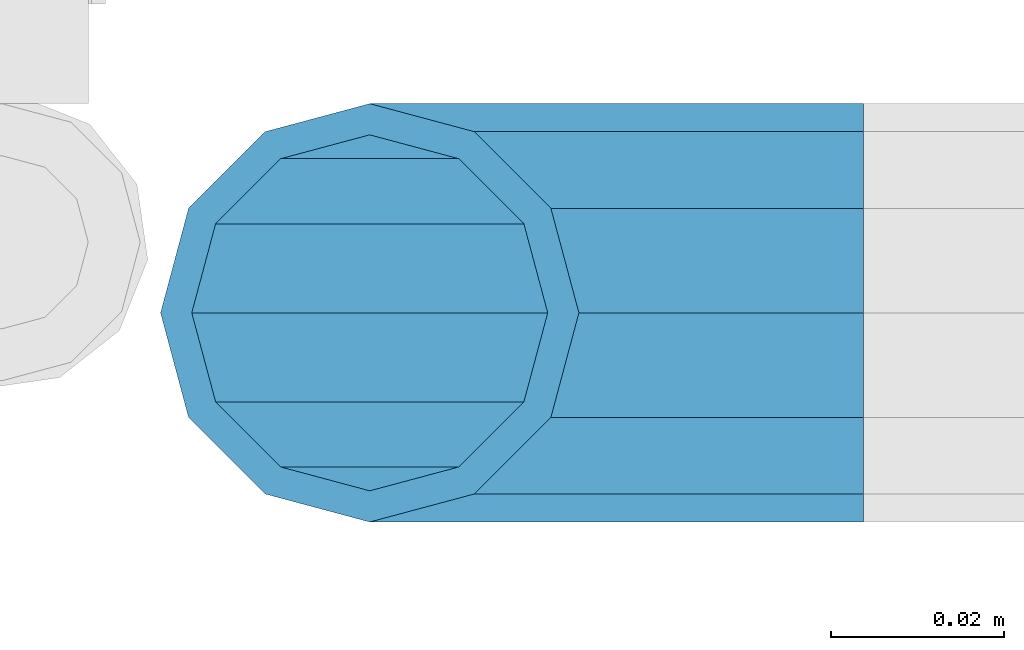
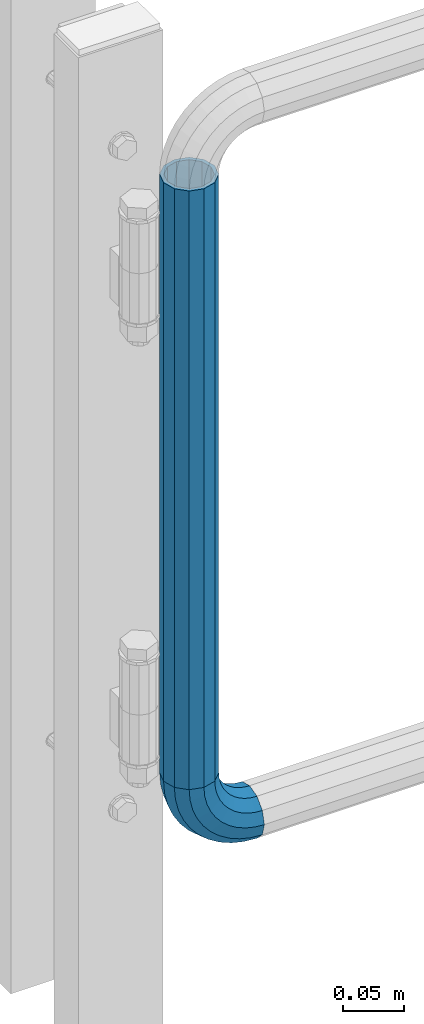
# One storey, part 145 of 208: 1 beam, 1 member.
"""IFC2X3 building model written with IfcOpenShell, lengths in millimetres."""

import ifcopenshell
import ifcopenshell.guid

model = None  # the IFC model being written
_history = None  # IfcOwnerHistory: only IFC2X3 demands one
_inside = {}  # id of a spatial element -> (the spatial element, [elements in it])
_under = {}  # id of a project, library or spatial element -> (it, [spatial elements below it])
_declared = {}  # id of a project -> (the project, [libraries it declares])
_typed = {}  # id of a type object -> (the type object, [elements of that type])
_made_of = {}  # id of a material, layer set ... -> (it, [elements and type objects made of it])


def new_model(schema):
    """Start an empty IFC model of exactly this schema.

    Asked for "IFC4X3", IfcOpenShell would pick the latest addendum, in which some entities
    have other attributes; the version numbers below select the first issue.
    IFC2X3 requires an IfcOwnerHistory on every rooted entity: one is made here for all.
    """
    global model, _history
    if schema == "IFC4X3":
        model = ifcopenshell.file(schema_version=(4, 3, 0, 0))
    else:
        model = ifcopenshell.file(schema=schema)
    _inside.clear()
    _under.clear()
    _declared.clear()
    _typed.clear()
    _made_of.clear()
    _history = None
    if model.schema == "IFC2X3":
        org = make("IfcOrganization", Name="unknown")
        user = make(
            "IfcPersonAndOrganization",
            ThePerson=make("IfcPerson", FamilyName="unknown"),
            TheOrganization=org,
        )
        app = make(
            "IfcApplication",
            ApplicationDeveloper=org,
            Version="unknown",
            ApplicationFullName="unknown",
            ApplicationIdentifier="unknown",
        )
        _history = make(
            "IfcOwnerHistory",
            OwningUser=user,
            OwningApplication=app,
            ChangeAction="ADDED",
            CreationDate=0,
        )
    return model


def make(cls, **values):
    """One entity of the class cls with the attributes given. An attribute that is None is left unset."""
    return model.create_entity(
        cls, **{name: value for name, value in values.items() if value is not None}
    )


def rooted(cls, **values):
    """An entity with a GlobalId (a new one), such as an element, a storey or a relation."""
    return make(cls, GlobalId=ifcopenshell.guid.new(), OwnerHistory=_history, **values)


def si_unit(unit_type, name, prefix=None):
    """IfcSIUnit, for example si_unit("LENGTHUNIT", "METRE", prefix="MILLI")."""
    return make("IfcSIUnit", UnitType=unit_type, Prefix=prefix, Name=name)


def assignment(units):
    """IfcUnitAssignment: the units of a project."""
    return None if units is None else make("IfcUnitAssignment", Units=units)


def point(xyz):
    """IfcCartesianPoint."""
    return None if xyz is None else make("IfcCartesianPoint", Coordinates=xyz)


def direction(xyz):
    """IfcDirection."""
    return None if xyz is None else make("IfcDirection", DirectionRatios=xyz)


def frame(location, z_axis=None, x_axis=None):
    """IfcAxis2Placement3D, a coordinate frame: its origin and axes. An axis left out is left unset."""
    return make(
        "IfcAxis2Placement3D",
        Location=point(location),
        Axis=direction(z_axis),
        RefDirection=direction(x_axis),
    )


def origin_with_axes():
    """The frame at (0, 0, 0) with the z axis (0, 0, 1) and the x axis (1, 0, 0) written out."""
    return frame((0.0, 0.0, 0.0), z_axis=(0.0, 0.0, 1.0), x_axis=(1.0, 0.0, 0.0))


def place(relative_to, where):
    """IfcLocalPlacement: puts the frame where relative to a parent placement (None: the world)."""
    return make(
        "IfcLocalPlacement", PlacementRelTo=relative_to, RelativePlacement=where
    )


def context(
    kind, dimensions, precision=None, world=None, true_north=None, identifier=None
):
    """IfcGeometricRepresentationContext, for example the 3D "Model" context."""
    return make(
        "IfcGeometricRepresentationContext",
        ContextIdentifier=identifier,
        ContextType=kind,
        CoordinateSpaceDimension=dimensions,
        Precision=precision,
        WorldCoordinateSystem=world,
        TrueNorth=true_north,
    )


def subcontext(parent, identifier, kind, view, scale=None):
    """IfcGeometricRepresentationSubContext, for example "Body" below "Model"."""
    return make(
        "IfcGeometricRepresentationSubContext",
        ContextIdentifier=identifier,
        ContextType=kind,
        ParentContext=parent,
        TargetScale=scale,
        TargetView=view,
    )


def project(units=None, contexts=None):
    """IfcProject with its units and contexts."""
    return rooted(
        "IfcProject",
        Name="project",
        RepresentationContexts=contexts,
        UnitsInContext=assignment(units),
    )


def spatial(cls, under=None, at=None, **own):
    """A site, building, storey or space (cls), placed at a placement, below another one or the project."""
    s = rooted(cls, ObjectPlacement=at, **own)
    if under is not None:
        _under.setdefault(under.id(), (under, []))[1].append(s)
    return s


def faces_of(points, faces, orient=None, outer=None):
    """IfcFace entities. A face is a list of loops; a loop is a list of indices into points, from 0.

    orient and outer hold one flag for each loop. By default every Orientation is true, the
    first loop of a face is its IfcFaceOuterBound and the others are IfcFaceBound.
    """
    made = []
    for i, loops in enumerate(faces):
        bounds = []
        for j, loop in enumerate(loops):
            is_outer = j == 0 if outer is None else outer[i][j]
            bounds.append(
                make(
                    "IfcFaceOuterBound" if is_outer else "IfcFaceBound",
                    Bound=make("IfcPolyLoop", Polygon=[points[k] for k in loop]),
                    Orientation=True if orient is None else orient[i][j],
                )
            )
        made.append(make("IfcFace", Bounds=bounds))
    return made


def faceted_brep(points, faces, orient=None, outer=None, voids=None):
    """IfcFacetedBrep: a solid bounded by flat faces; with voids (closed shells), ...WithVoids."""
    shared = [point(p) for p in points]
    hull = make("IfcClosedShell", CfsFaces=faces_of(shared, faces, orient, outer))
    if voids is None:
        return make("IfcFacetedBrep", Outer=hull)
    return make(
        "IfcFacetedBrepWithVoids",
        Outer=hull,
        Voids=[
            make(cls, CfsFaces=faces_of(shared, fs, o, b)) for cls, fs, o, b in voids
        ],
    )


def shape(context_of_items, identifier, shape_type, items):
    """IfcShapeRepresentation: the items that make up one representation, for example the "Body"."""
    return make(
        "IfcShapeRepresentation",
        ContextOfItems=context_of_items,
        RepresentationIdentifier=identifier,
        RepresentationType=shape_type,
        Items=items,
    )


def material(Name=None, Category=None):
    """IfcMaterial."""
    return make("IfcMaterial", Name=Name, Category=Category)


def made_of(thing, what):
    """Note that an element or type object is made of a material, layer set ...; save() writes the relation."""
    if what is not None:
        _made_of.setdefault(what.id(), (what, []))[1].append(thing)
    return thing


def type_object(cls, material=None, **own):
    """A type object (cls), such as IfcWallType, which elements share."""
    return made_of(rooted(cls, **own), material)


def element(
    cls,
    number,
    at=None,
    inside=None,
    cuts=None,
    type_object=None,
    material=None,
    context=None,
    identifier="Body",
    shape_type=None,
    held_by="IfcProductDefinitionShape",
    body=None,
    shapes=None,
    **own,
):
    """One element of the class cls, such as IfcWall. Its Tag is "e" and its number.

    at: its placement. inside: the storey or other place that contains it. cuts: it is an
    opening in that element (IfcRelVoidsElement). A single representation is given by context,
    identifier, shape_type and body (its items); several are given by shapes. held_by: the class
    of the entity that holds the representations. save() writes the other relations.
    """
    e = rooted(cls, Tag="e%d" % number, ObjectPlacement=at, **own)
    if body is not None:
        shapes = [shape(context, identifier, shape_type, body)]
    if shapes is not None:
        e.Representation = make(held_by, Representations=shapes)
    if inside is not None:
        _inside.setdefault(inside.id(), (inside, []))[1].append(e)
    if cuts is not None:
        rooted(
            "IfcRelVoidsElement", RelatingBuildingElement=cuts, RelatedOpeningElement=e
        )
    if type_object is not None:
        _typed.setdefault(type_object.id(), (type_object, []))[1].append(e)
    return made_of(e, material)


def aggregate(whole, parts):
    """IfcRelAggregates: a whole, such as a stair, and the parts it consists of."""
    return rooted("IfcRelAggregates", RelatingObject=whole, RelatedObjects=parts)


def save(model, path):
    """Write the relations noted so far, then the file.

    IfcRelAggregates (storeys below a building ...), IfcRelContainedInSpatialStructure (elements
    in a storey), IfcRelDefinesByType, IfcRelAssociatesMaterial and IfcRelDeclares: one each for
    every whole, place, type object, material and project.
    """
    for whole, parts in _under.values():
        aggregate(whole, parts)
    for where, things in _inside.values():
        rooted(
            "IfcRelContainedInSpatialStructure",
            RelatedElements=things,
            RelatingStructure=where,
        )
    for kind, things in _typed.values():
        rooted("IfcRelDefinesByType", RelatedObjects=things, RelatingType=kind)
    for what, things in _made_of.values():
        rooted("IfcRelAssociatesMaterial", RelatedObjects=things, RelatingMaterial=what)
    for by, libraries in _declared.values():
        rooted("IfcRelDeclares", RelatingContext=by, RelatedDefinitions=libraries)
    model.write(path)


model = new_model("IFC2X3")

# Units and contexts
model_context = context("Model", 3, precision=1e-05, world=origin_with_axes())
body_context = subcontext(model_context, "Body", "Model", "MODEL_VIEW")
ifc_project = project(units=[si_unit("LENGTHUNIT", "METRE", prefix="MILLI"), si_unit("AREAUNIT", "SQUARE_METRE"), si_unit("VOLUMEUNIT", "CUBIC_METRE"), si_unit("MASSUNIT", "GRAM", prefix="KILO"), si_unit("TIMEUNIT", "SECOND"), si_unit("PLANEANGLEUNIT", "RADIAN"), si_unit("SOLIDANGLEUNIT", "STERADIAN"), si_unit("THERMODYNAMICTEMPERATUREUNIT", "DEGREE_CELSIUS"), si_unit("LUMINOUSINTENSITYUNIT", "LUMEN")], contexts=[model_context])

# Site, building, storey
site_placement = place(None, origin_with_axes())
site = spatial("IfcSite", under=ifc_project, at=site_placement, CompositionType="ELEMENT")
building_placement = place(site_placement, origin_with_axes())
building = spatial("IfcBuilding", under=site, at=building_placement, Name="Standard", CompositionType="ELEMENT")
storey_placement = place(building_placement, origin_with_axes())
storey = spatial("IfcBuildingStorey", under=building, at=storey_placement, Name="Undefined", CompositionType="ELEMENT", Elevation=0.0)

# Member
ifc_material = material()
member_type = type_object("IfcMemberType", PredefinedType="NOTDEFINED")
member_placement = place(storey_placement, frame((-15494.7539827644, 2941.85399999618, 224.650006544463), z_axis=(0.0, -1.0, 0.0), x_axis=(-0.707106781186548, 0.0, 0.707106781186548)))
element("IfcMember", 1, at=member_placement, inside=storey, type_object=member_type, material=ifc_material, context=body_context, shape_type="Brep", body=[
    faceted_brep([(17.0766287656552, -17.0766287656552, 0.0), (14.7887943220539, -14.7887943220539, -12.0749999999998), (19.0945697419538, -11.1113146999724, -12.0749999999998), (20.9963409898282, -13.7288782624146, 0.0), (8.53831438282759, -8.53831438282759, -20.9145135013941), (13.8988340683954, -3.95999805533756, -20.9145135013941), (0.0, 0.0, -24.1500000000001), (6.80132714696265, 5.80888215173945, -24.1500000000001), (-8.53831438282759, 8.53831438282759, -20.9145135013941), (-0.296179774470147, 15.5777623588165, -20.9145135013941), (-14.7887943220521, 14.7887943220521, -12.0749999999998), (-5.49191544802852, 22.7290790034513, -12.0749999999998), (-17.0766287656552, 17.0766287656552, 0.0), (-7.39368669589931, 25.3466425658935, 0.0), (-14.7887943220521, 14.7887943220521, 12.0749999999998), (-5.49191544802852, 22.7290790034513, 12.0749999999998), (-8.53831438282759, 8.53831438282759, 20.9145135013941), (-0.296179774470147, 15.5777623588165, 20.9145135013941), (0.0, 0.0, 24.1500000000001), (6.80132714696265, 5.80888215173945, 24.1500000000001), (8.53831438282759, -8.53831438282759, 20.9145135013941), (13.8988340683954, -3.95999805533756, 20.9145135013941), (14.7887943220539, -14.7887943220539, 12.0749999999998), (19.0945697419538, -11.1113146999724, 12.0749999999998), (14.5310443533836, -14.5310443533836, 0.0), (12.5842535535485, -12.5842535535485, 10.2750000000001), (17.2620366843166, -8.58904933077247, 10.2750000000001), (18.8803140815726, -10.8164170826676, 0.0), (7.26552217669268, -7.26552217669268, 17.7968220477701), (12.8408206142685, -2.50376746546499, 17.7968220477701), (0.0, 0.0, 20.5500000000002), (6.80132714696265, 5.80888215173945, 20.5500000000002), (-7.26552217669087, 7.26552217669087, 17.7968220477701), (0.761833679658594, 14.1215317689421, 17.7968220477701), (-12.5842535535485, 12.5842535535485, 10.2750000000001), (-3.65938239039133, 20.2068136342514, 10.2750000000001), (-14.5310443533836, 14.5310443533836, 0.0), (-5.27765978764546, 22.4341813861447, 0.0), (-12.5842535535485, 12.5842535535485, -10.2750000000001), (-3.65938239039133, 20.2068136342514, -10.2750000000001), (-7.26552217669087, 7.26552217669087, -17.7968220477701), (0.761833679658594, 14.1215317689421, -17.7968220477701), (0.0, 0.0, -20.5500000000002), (6.80132714696265, 5.80888215173945, -20.5500000000002), (7.26552217669268, -7.26552217669268, -17.7968220477701), (12.8408206142685, -2.50376746546499, -17.7968220477701), (12.5842535535485, -12.5842535535485, -10.2750000000001), (17.2620366843166, -8.58904933077247, -10.2750000000001), (23.9226184787876, -8.15268262886457, -12.0749999999998), (25.3914986111904, -11.0355222080452, 0.0), (19.9095633268353, -0.27661842847192, -20.9145135013941), (14.4276280424801, 10.482285351105, -24.1500000000001), (8.94569275812501, 21.2411891306783, -20.9145135013941), (4.93263760617265, 29.117253331071, -12.0749999999998), (3.46375747377169, 32.0000929102534, 0.0), (4.93263760617265, 29.117253331071, 12.0749999999998), (8.94569275812501, 21.2411891306783, 20.9145135013941), (14.4276280424801, 10.482285351105, 24.1500000000001), (19.9095633268353, -0.27661842847192, 20.9145135013941), (23.9226184787876, -8.15268262886457, 12.0749999999998), (22.5072161777225, -5.3747992032786, 10.2750000000001), (23.7571328121267, -7.82789872096691, 0.0), (19.0923804273043, 1.32719331506814, 17.7968220477701), (14.4276280424801, 10.482285351105, 20.5500000000002), (9.76287565765597, 19.6373773871383, 17.7968220477701), (6.34803990723776, 26.3393699054886, 10.2750000000001), (5.0981232728318, 28.7924694231751, 0.0), (6.34803990723776, 26.3393699054886, -10.2750000000001), (9.76287565765597, 19.6373773871383, -17.7968220477701), (14.4276280424801, 10.482285351105, -20.5500000000002), (19.0923804273043, 1.32719331506814, -17.7968220477701), (22.5072161777225, -5.3747992032786, -10.2750000000001), (29.1540579492776, -5.98574944945176, -12.0749999999998), (30.1538782624175, -9.06287996733772, 0.0), (26.422498055339, 2.42112746692692, -20.9145135013941), (22.6911178482624, 13.9051349011897, -24.1500000000001), (18.9597376411857, 25.3891423354562, -20.9145135013941), (16.2281777472472, 33.7960192518349, -12.0749999999998), (15.2283574341091, 36.873149769719, 0.0), (16.2281777472472, 33.7960192518349, 12.0749999999998), (18.9597376411857, 25.3891423354562, 20.9145135013941), (22.6911178482624, 13.9051349011897, 24.1500000000001), (26.422498055339, 2.42112746692692, 20.9145135013941), (29.1540579492776, -5.98574944945176, 12.0749999999998), (28.1906383068908, -3.0206486766856, 10.2750000000001), (29.041417082668, -5.63907650867441, 0.0), (25.8662674654661, 4.13302919625858, 17.7968220477701), (22.6911178482624, 13.9051349011897, 20.5500000000002), (19.5159682310605, 23.6772406061227, 17.7968220477701), (17.1915973896339, 30.8309184790687, 10.2750000000001), (16.3408186138568, 33.4493463110575, 0.0), (17.1915973896339, 30.8309184790687, -10.2750000000001), (19.5159682310605, 23.6772406061227, -17.7968220477701), (22.6911178482624, 13.9051349011897, -20.5500000000002), (25.8662674654661, 4.13302919625858, -17.7968220477701), (28.1906383068908, -3.0206486766856, -10.2750000000001), (34.660072751507, -4.66387224825667, -12.0749999999998), (35.1662143510621, -7.85952453908249, 0.0), (33.2772681857005, 4.06681217360347, -20.9145135013941), (31.3883220203406, 15.9931488862876, -24.1500000000001), (29.4993758549808, 27.9194855989754, -20.9145135013941), (28.1165712891743, 36.6501700208355, -12.0749999999998), (27.6104296896192, 39.8458223116613, 0.0), (28.1165712891743, 36.6501700208355, 12.0749999999998), (29.4993758549808, 27.9194855989754, 20.9145135013941), (31.3883220203406, 15.9931488862876, 24.1500000000001), (33.2772681857005, 4.06681217360347, 20.9145135013941), (34.660072751507, -4.66387224825667, 12.0749999999998), (34.1723583568, -1.58456474993909, 10.2750000000001), (34.6030502769172, -4.30384651293934, 0.0), (32.995686148628, 5.84465118667504, 17.7968220477701), (31.3883220203406, 15.9931488862876, 20.5500000000002), (29.7809578920533, 26.1416465859038, 17.7968220477701), (28.6042856838831, 33.5708625225197, 10.2750000000001), (28.1735937637659, 36.29014428552, 0.0), (28.6042856838831, 33.5708625225197, -10.2750000000001), (29.7809578920533, 26.1416465859038, -17.7968220477701), (31.3883220203406, 15.9931488862876, -20.5500000000002), (32.995686148628, 5.84465118667504, -17.7968220477701), (34.1723583568, -1.58456474993909, -10.2750000000001), (40.3050865276346, -4.21960002902779, -12.0749999999998), (40.3050865276346, -7.45508652763237, 0.0), (40.3050865276327, 4.61991347236653, -20.9145135013941), (40.3050865276327, 16.6949134723673, -24.1500000000001), (40.3050865276346, 28.7699134723662, -20.9145135013941), (40.3050865276346, 37.6094269737623, -12.0749999999998), (40.3050865276346, 40.8449134723669, 0.0), (40.3050865276346, 37.6094269737623, 12.0749999999998), (40.3050865276346, 28.7699134723662, 20.9145135013941), (40.3050865276327, 16.6949134723673, 24.1500000000001), (40.3050865276327, 4.61991347236653, 20.9145135013941), (40.3050865276346, -4.21960002902779, 12.0749999999998), (40.3050865276327, -1.10190857540329, 10.2750000000001), (40.3050865276346, -3.85508652763383, 0.0), (40.3050865276346, 6.41991347236763, 17.7968220477701), (40.3050865276327, 16.6949134723673, 20.5500000000002), (40.3050865276346, 26.9699134723669, 17.7968220477701), (40.3050865276346, 34.491735520136, 10.2750000000001), (40.3050865276327, 37.2449134723665, 0.0), (40.3050865276346, 34.491735520136, -10.2750000000001), (40.3050865276346, 26.9699134723669, -17.7968220477701), (40.3050865276327, 16.6949134723673, -20.5500000000002), (40.3050865276346, 6.41991347236763, -17.7968220477701), (40.3050865276327, -1.10190857540329, -10.2750000000001), (45.9501003037603, -4.66387224825485, -12.0749999999998), (45.4439587042052, -7.8595245390843, 0.0), (47.3329048695668, 4.06681217360529, -20.9145135013941), (49.2218510349267, 15.9931488862894, -24.1500000000001), (51.1107972002883, 27.9194855989754, -20.9145135013941), (52.4936017660948, 36.6501700208355, -12.0749999999998), (52.9997433656481, 39.8458223116631, 0.0), (52.4936017660948, 36.6501700208355, 12.0749999999998), (51.1107972002883, 27.9194855989754, 20.9145135013941), (49.2218510349267, 15.9931488862894, 24.1500000000001), (47.3329048695668, 4.06681217360529, 20.9145135013941), (45.9501003037603, -4.66387224825485, 12.0749999999998), (46.4378146984691, -1.58456474993909, 10.2750000000001), (46.0071227783501, -4.30384651294116, 0.0), (47.6144869066393, 5.84465118667322, 17.7968220477701), (49.2218510349267, 15.9931488862894, 20.5500000000002), (50.8292151632158, 26.1416465859038, 17.7968220477701), (52.0058873713861, 33.5708625225197, 10.2750000000001), (52.4365792915032, 36.29014428552, 0.0), (52.0058873713861, 33.5708625225197, -10.2750000000001), (50.8292151632158, 26.1416465859038, -17.7968220477701), (49.2218510349267, 15.9931488862894, -20.5500000000002), (47.6144869066393, 5.84465118667322, -17.7968220477701), (46.4378146984691, -1.58456474993909, -10.2750000000001), (51.4561151059897, -5.98574944945358, -12.0749999999998), (50.4562947928516, -9.06287996733772, 0.0), (54.1876749999301, 2.42112746692692, -20.9145135013941), (57.9190552070068, 13.9051349011897, -24.1500000000001), (61.6504354140834, 25.3891423354562, -20.9145135013941), (64.3819953080219, 33.7960192518349, -12.0749999999998), (65.3818156211601, 36.873149769719, 0.0), (64.3819953080219, 33.7960192518349, 12.0749999999998), (61.6504354140834, 25.3891423354562, 20.9145135013941), (57.9190552070068, 13.9051349011897, 24.1500000000001), (54.1876749999301, 2.42112746692692, 20.9145135013941), (51.4561151059897, -5.98574944945358, 12.0749999999998), (52.4195347483783, -3.0206486766856, 10.2750000000001), (51.5687559726011, -5.63907650867441, 0.0), (54.743905589803, 4.13302919625858, 17.7968220477701), (57.9190552070068, 13.9051349011897, 20.5500000000002), (61.0942048242086, 23.6772406061227, 17.7968220477701), (63.4185756656334, 30.8309184790669, 10.2750000000001), (64.2693544414105, 33.4493463110557, 0.0), (63.4185756656334, 30.8309184790669, -10.2750000000001), (61.0942048242086, 23.6772406061227, -17.7968220477701), (57.9190552070068, 13.9051349011897, -20.5500000000002), (54.743905589803, 4.13302919625858, -17.7968220477701), (52.4195347483783, -3.0206486766856, -10.2750000000001), (56.6875545764815, -8.15268262886457, -12.0749999999998), (55.2186744440787, -11.0355222080452, 0.0), (60.7006097284338, -0.27661842847192, -20.9145135013941), (66.182545012789, 10.482285351105, -24.1500000000001), (71.6644802971441, 21.2411891306783, -20.9145135013941), (75.6775354490965, 29.117253331071, -12.0749999999998), (77.1464155814974, 32.0000929102534, 0.0), (75.6775354490965, 29.117253331071, 12.0749999999998), (71.6644802971441, 21.2411891306783, 20.9145135013941), (66.182545012789, 10.482285351105, 24.1500000000001), (60.7006097284338, -0.27661842847192, 20.9145135013941), (56.6875545764815, -8.15268262886457, 12.0749999999998), (58.1029568775466, -5.3747992032786, 10.2750000000001), (56.8530402431425, -7.82789872096691, 0.0), (61.5177926279648, 1.32719331506814, 17.7968220477701), (66.182545012789, 10.482285351105, 20.5500000000002), (70.8472973976113, 19.6373773871401, 17.7968220477701), (74.2621331480332, 26.3393699054868, 10.2750000000001), (75.5120497824355, 28.7924694231733, 0.0), (74.2621331480332, 26.3393699054868, -10.2750000000001), (70.8472973976113, 19.6373773871401, -17.7968220477701), (66.182545012789, 10.482285351105, -20.5500000000002), (61.5177926279648, 1.32719331506814, -17.7968220477701), (58.1029568775466, -5.3747992032786, -10.2750000000001), (61.5156033133135, -11.1113146999742, -12.0749999999998), (59.6138320654427, -13.7288782624164, 0.0), (66.7113389868737, -3.95999805533756, -20.9145135013941), (73.8088459083046, 5.80888215173763, -24.1500000000001), (80.9063528297374, 15.5777623588183, -20.9145135013941), (86.1020885032976, 22.7290790034513, -12.0749999999998), (88.0038597511684, 25.3466425658935, 0.0), (86.1020885032976, 22.7290790034513, 12.0749999999998), (80.9063528297374, 15.5777623588183, 20.9145135013941), (73.8088459083046, 5.80888215173763, 24.1500000000001), (66.7113389868737, -3.95999805533756, 20.9145135013941), (61.5156033133135, -11.1113146999742, 12.0749999999998), (63.3481363709525, -8.58904933077247, 10.2750000000001), (61.7298589736947, -10.8164170826658, 0.0), (67.7693524409988, -2.50376746546317, 17.7968220477701), (73.8088459083046, 5.80888215173763, 20.5500000000002), (79.8483393756105, 14.1215317689421, 17.7968220477701), (84.2695554456586, 20.2068136342532, 10.2750000000001), (85.8878328429146, 22.4341813861447, 0.0), (84.2695554456586, 20.2068136342532, -10.2750000000001), (79.8483393756105, 14.1215317689421, -17.7968220477701), (73.8088459083046, 5.80888215173763, -20.5500000000002), (67.7693524409988, -2.50376746546317, -17.7968220477701), (63.3481363709525, -8.58904933077247, -10.2750000000001), (65.8213787332152, -14.7887943220539, -12.0749999999998), (63.5335442896121, -17.0766287656534, 0.0), (72.0718586724379, -8.53831438282759, -20.9145135013941), (80.6101730552673, 1.81898940354586e-12, -24.1500000000001), (89.1484874380967, 8.53831438282759, -20.9145135013941), (95.3989673773231, 14.7887943220539, -12.0749999999998), (97.6868018209225, 17.0766287656534, 0.0), (95.3989673773231, 14.7887943220539, 12.0749999999998), (89.1484874380967, 8.53831438282759, 20.9145135013941), (80.6101730552673, 1.81898940354586e-12, 24.1500000000001), (72.0718586724379, -8.53831438282759, 20.9145135013941), (65.8213787332152, -14.7887943220539, 12.0749999999998), (68.0259195017188, -12.5842535535503, 10.2750000000001), (66.0791287018856, -14.5310443533836, 0.0), (73.3446508785764, -7.26552217669268, 17.7968220477701), (80.6101730552673, 1.81898940354586e-12, 20.5500000000002), (87.8756952319582, 7.26552217669268, 17.7968220477701), (93.1944266088158, 12.5842535535503, 10.2750000000001), (95.141217408649, 14.5310443533836, 0.0), (93.1944266088158, 12.5842535535503, -10.2750000000001), (87.8756952319582, 7.26552217669268, -17.7968220477701), (80.6101730552673, 1.81898940354586e-12, -20.5500000000002), (73.3446508785764, -7.26552217669268, -17.7968220477701), (68.0259195017188, -12.5842535535503, -10.2750000000001)], [[[0, 1, 2, 3]], [[1, 4, 5, 2]], [[4, 6, 7, 5]], [[6, 8, 9, 7]], [[8, 10, 11, 9]], [[10, 12, 13, 11]], [[12, 14, 15, 13]], [[14, 16, 17, 15]], [[16, 18, 19, 17]], [[18, 20, 21, 19]], [[20, 22, 23, 21]], [[22, 0, 3, 23]], [[24, 25, 26, 27]], [[25, 28, 29, 26]], [[28, 30, 31, 29]], [[30, 32, 33, 31]], [[32, 34, 35, 33]], [[34, 36, 37, 35]], [[36, 38, 39, 37]], [[38, 40, 41, 39]], [[40, 42, 43, 41]], [[42, 44, 45, 43]], [[44, 46, 47, 45]], [[46, 24, 27, 47]], [[22, 20, 18, 16, 14, 12, 10, 8, 6, 4, 1, 0], [46, 44, 42, 40, 38, 36, 34, 32, 30, 28, 25, 24]], [[3, 2, 48, 49]], [[2, 5, 50, 48]], [[5, 7, 51, 50]], [[7, 9, 52, 51]], [[9, 11, 53, 52]], [[11, 13, 54, 53]], [[13, 15, 55, 54]], [[15, 17, 56, 55]], [[17, 19, 57, 56]], [[19, 21, 58, 57]], [[21, 23, 59, 58]], [[23, 3, 49, 59]], [[27, 26, 60, 61]], [[26, 29, 62, 60]], [[29, 31, 63, 62]], [[31, 33, 64, 63]], [[33, 35, 65, 64]], [[35, 37, 66, 65]], [[37, 39, 67, 66]], [[39, 41, 68, 67]], [[41, 43, 69, 68]], [[43, 45, 70, 69]], [[45, 47, 71, 70]], [[47, 27, 61, 71]], [[49, 48, 72, 73]], [[48, 50, 74, 72]], [[50, 51, 75, 74]], [[51, 52, 76, 75]], [[52, 53, 77, 76]], [[53, 54, 78, 77]], [[54, 55, 79, 78]], [[55, 56, 80, 79]], [[56, 57, 81, 80]], [[57, 58, 82, 81]], [[58, 59, 83, 82]], [[59, 49, 73, 83]], [[61, 60, 84, 85]], [[60, 62, 86, 84]], [[62, 63, 87, 86]], [[63, 64, 88, 87]], [[64, 65, 89, 88]], [[65, 66, 90, 89]], [[66, 67, 91, 90]], [[67, 68, 92, 91]], [[68, 69, 93, 92]], [[69, 70, 94, 93]], [[70, 71, 95, 94]], [[71, 61, 85, 95]], [[73, 72, 96, 97]], [[72, 74, 98, 96]], [[74, 75, 99, 98]], [[75, 76, 100, 99]], [[76, 77, 101, 100]], [[77, 78, 102, 101]], [[78, 79, 103, 102]], [[79, 80, 104, 103]], [[80, 81, 105, 104]], [[81, 82, 106, 105]], [[82, 83, 107, 106]], [[83, 73, 97, 107]], [[85, 84, 108, 109]], [[84, 86, 110, 108]], [[86, 87, 111, 110]], [[87, 88, 112, 111]], [[88, 89, 113, 112]], [[89, 90, 114, 113]], [[90, 91, 115, 114]], [[91, 92, 116, 115]], [[92, 93, 117, 116]], [[93, 94, 118, 117]], [[94, 95, 119, 118]], [[95, 85, 109, 119]], [[97, 96, 120, 121]], [[96, 98, 122, 120]], [[98, 99, 123, 122]], [[99, 100, 124, 123]], [[100, 101, 125, 124]], [[101, 102, 126, 125]], [[102, 103, 127, 126]], [[103, 104, 128, 127]], [[104, 105, 129, 128]], [[105, 106, 130, 129]], [[106, 107, 131, 130]], [[107, 97, 121, 131]], [[109, 108, 132, 133]], [[108, 110, 134, 132]], [[110, 111, 135, 134]], [[111, 112, 136, 135]], [[112, 113, 137, 136]], [[113, 114, 138, 137]], [[114, 115, 139, 138]], [[115, 116, 140, 139]], [[116, 117, 141, 140]], [[117, 118, 142, 141]], [[118, 119, 143, 142]], [[119, 109, 133, 143]], [[121, 120, 144, 145]], [[120, 122, 146, 144]], [[122, 123, 147, 146]], [[123, 124, 148, 147]], [[124, 125, 149, 148]], [[125, 126, 150, 149]], [[126, 127, 151, 150]], [[127, 128, 152, 151]], [[128, 129, 153, 152]], [[129, 130, 154, 153]], [[130, 131, 155, 154]], [[131, 121, 145, 155]], [[133, 132, 156, 157]], [[132, 134, 158, 156]], [[134, 135, 159, 158]], [[135, 136, 160, 159]], [[136, 137, 161, 160]], [[137, 138, 162, 161]], [[138, 139, 163, 162]], [[139, 140, 164, 163]], [[140, 141, 165, 164]], [[141, 142, 166, 165]], [[142, 143, 167, 166]], [[143, 133, 157, 167]], [[145, 144, 168, 169]], [[144, 146, 170, 168]], [[146, 147, 171, 170]], [[147, 148, 172, 171]], [[148, 149, 173, 172]], [[149, 150, 174, 173]], [[150, 151, 175, 174]], [[151, 152, 176, 175]], [[152, 153, 177, 176]], [[153, 154, 178, 177]], [[154, 155, 179, 178]], [[155, 145, 169, 179]], [[157, 156, 180, 181]], [[156, 158, 182, 180]], [[158, 159, 183, 182]], [[159, 160, 184, 183]], [[160, 161, 185, 184]], [[161, 162, 186, 185]], [[162, 163, 187, 186]], [[163, 164, 188, 187]], [[164, 165, 189, 188]], [[165, 166, 190, 189]], [[166, 167, 191, 190]], [[167, 157, 181, 191]], [[169, 168, 192, 193]], [[168, 170, 194, 192]], [[170, 171, 195, 194]], [[171, 172, 196, 195]], [[172, 173, 197, 196]], [[173, 174, 198, 197]], [[174, 175, 199, 198]], [[175, 176, 200, 199]], [[176, 177, 201, 200]], [[177, 178, 202, 201]], [[178, 179, 203, 202]], [[179, 169, 193, 203]], [[181, 180, 204, 205]], [[180, 182, 206, 204]], [[182, 183, 207, 206]], [[183, 184, 208, 207]], [[184, 185, 209, 208]], [[185, 186, 210, 209]], [[186, 187, 211, 210]], [[187, 188, 212, 211]], [[188, 189, 213, 212]], [[189, 190, 214, 213]], [[190, 191, 215, 214]], [[191, 181, 205, 215]], [[193, 192, 216, 217]], [[192, 194, 218, 216]], [[194, 195, 219, 218]], [[195, 196, 220, 219]], [[196, 197, 221, 220]], [[197, 198, 222, 221]], [[198, 199, 223, 222]], [[199, 200, 224, 223]], [[200, 201, 225, 224]], [[201, 202, 226, 225]], [[202, 203, 227, 226]], [[203, 193, 217, 227]], [[205, 204, 228, 229]], [[204, 206, 230, 228]], [[206, 207, 231, 230]], [[207, 208, 232, 231]], [[208, 209, 233, 232]], [[209, 210, 234, 233]], [[210, 211, 235, 234]], [[211, 212, 236, 235]], [[212, 213, 237, 236]], [[213, 214, 238, 237]], [[214, 215, 239, 238]], [[215, 205, 229, 239]], [[217, 216, 240, 241]], [[216, 218, 242, 240]], [[218, 219, 243, 242]], [[219, 220, 244, 243]], [[220, 221, 245, 244]], [[221, 222, 246, 245]], [[222, 223, 247, 246]], [[223, 224, 248, 247]], [[224, 225, 249, 248]], [[225, 226, 250, 249]], [[226, 227, 251, 250]], [[227, 217, 241, 251]], [[229, 228, 252, 253]], [[228, 230, 254, 252]], [[230, 231, 255, 254]], [[231, 232, 256, 255]], [[232, 233, 257, 256]], [[233, 234, 258, 257]], [[234, 235, 259, 258]], [[235, 236, 260, 259]], [[236, 237, 261, 260]], [[237, 238, 262, 261]], [[238, 239, 263, 262]], [[239, 229, 253, 263]], [[242, 243, 244, 245, 246, 247, 248, 249, 250, 251, 241, 240], [254, 255, 256, 257, 258, 259, 260, 261, 262, 263, 253, 252]]]),
])

# Beam
beam_type = type_object("IfcBeamType", PredefinedType="NOTDEFINED")
beam_placement = place(storey_placement, frame((-15551.7539827644, 2941.85399999618, 878.350006544462), z_axis=(1.0, 0.0, 0.0), x_axis=(0.0, 0.0, -1.0)))
element("IfcBeam", 2, at=beam_placement, inside=storey, type_object=beam_type, material=ifc_material, context=body_context, shape_type="Brep", body=[
    faceted_brep([(0.0, -20.5500000000002, 0.0), (0.0, -17.7968220477701, 10.2749999999996), (596.700000000001, -17.7968220477701, 10.2749999999996), (596.700000000001, -20.5500000000002, 0.0), (0.0, -10.2750000000001, 17.7968220477705), (596.700000000001, -10.2750000000001, 17.7968220477705), (0.0, 0.0, 20.5500000000002), (596.700000000001, 0.0, 20.5499999999993), (0.0, 10.2750000000001, 17.7968220477705), (596.700000000001, 10.2750000000001, 17.7968220477705), (0.0, 17.7968220477701, 10.2749999999996), (596.700000000001, 17.7968220477701, 10.2749999999996), (0.0, 20.5500000000002, 0.0), (596.700000000001, 20.5500000000002, 0.0), (0.0, 17.7968220477701, -10.2749999999996), (596.700000000001, 17.7968220477701, -10.2749999999996), (0.0, 10.2750000000001, -17.7968220477705), (596.700000000001, 10.2750000000001, -17.7968220477705), (0.0, 0.0, -20.5500000000002), (596.700000000001, 0.0, -20.5499999999993), (0.0, -10.2750000000001, -17.7968220477705), (596.700000000001, -10.2750000000001, -17.7968220477705), (0.0, -17.7968220477701, -10.2749999999996), (596.700000000001, -17.7968220477701, -10.2749999999996), (0.0, -24.1500000000001, 0.0), (0.0, -20.9145135013941, -12.0750000000007), (596.700000000001, -20.9145135013941, -12.0750000000007), (596.700000000001, -24.1500000000001, 0.0), (0.0, -12.0749999999998, -20.914513501395), (596.700000000001, -12.0749999999998, -20.914513501395), (0.0, 0.0, -24.1500000000001), (596.700000000001, 0.0, -24.1499999999996), (0.0, 12.0749999999998, -20.914513501395), (596.700000000001, 12.0749999999998, -20.914513501395), (0.0, 20.9145135013941, -12.0750000000007), (596.700000000001, 20.9145135013941, -12.0750000000007), (0.0, 24.1500000000001, 0.0), (596.700000000001, 24.1500000000001, 0.0), (0.0, 20.9145135013941, 12.0750000000007), (596.700000000001, 20.9145135013941, 12.0750000000007), (0.0, 12.0749999999998, 20.914513501395), (596.700000000001, 12.0749999999998, 20.914513501395), (0.0, 0.0, 24.1500000000001), (596.700000000001, 0.0, 24.1499999999996), (0.0, -12.0749999999998, 20.914513501395), (596.700000000001, -12.0749999999998, 20.914513501395), (0.0, -20.9145135013941, 12.0750000000007), (596.700000000001, -20.9145135013941, 12.0750000000007)], [[[0, 1, 2, 3]], [[1, 4, 5, 2]], [[4, 6, 7, 5]], [[6, 8, 9, 7]], [[8, 10, 11, 9]], [[10, 12, 13, 11]], [[12, 14, 15, 13]], [[14, 16, 17, 15]], [[16, 18, 19, 17]], [[18, 20, 21, 19]], [[20, 22, 23, 21]], [[22, 0, 3, 23]], [[24, 25, 26, 27]], [[25, 28, 29, 26]], [[28, 30, 31, 29]], [[30, 32, 33, 31]], [[32, 34, 35, 33]], [[34, 36, 37, 35]], [[36, 38, 39, 37]], [[38, 40, 41, 39]], [[40, 42, 43, 41]], [[42, 44, 45, 43]], [[44, 46, 47, 45]], [[46, 24, 27, 47]], [[29, 31, 33, 35, 37, 39, 41, 43, 45, 47, 27, 26], [5, 7, 9, 11, 13, 15, 17, 19, 21, 23, 3, 2]], [[46, 44, 42, 40, 38, 36, 34, 32, 30, 28, 25, 24], [22, 20, 18, 16, 14, 12, 10, 8, 6, 4, 1, 0]]]),
])

save(model, "model.ifc")
